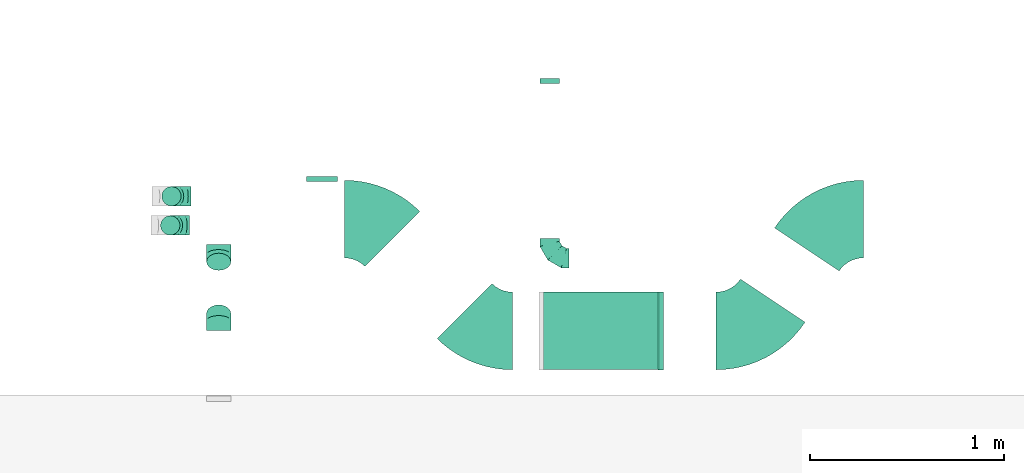
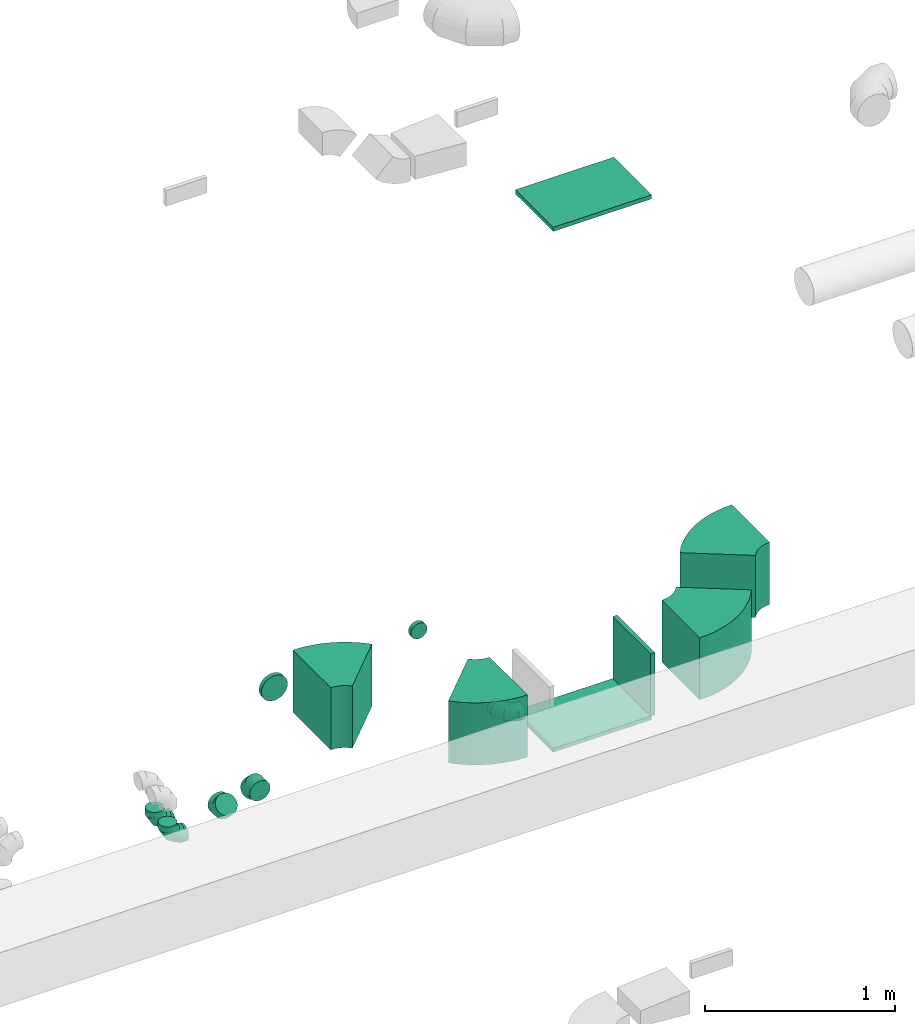
# One storey, part 33 of 62: 14 flow fittings.
"""IFC2X3 building model written with IfcOpenShell, lengths in millimetres."""

from ifc_helpers import new_model, entity, si_unit, converted_unit, derived_unit, direction, frame, frame_2d, origin, origin_2d_with_axis, place, context, subcontext, project, spatial, polyline, circle_curve, parameter, trimmed, segment, composite_curve, rectangle, outline, extrude, faceted_brep, source, transform, mapped, material, type_object, type_shapes, element, save


model = new_model("IFC2X3")

# Units and contexts
model_context = context("Model", 3, precision=0.01, world=origin(), true_north=direction((6.12303176911189e-17, 1.0)))
body_context = subcontext(model_context, "Body", "Model", "MODEL_VIEW")
ifc_project = project(units=[si_unit("LENGTHUNIT", "METRE", prefix="MILLI"), si_unit("AREAUNIT", "SQUARE_METRE"), si_unit("VOLUMEUNIT", "CUBIC_METRE"), converted_unit("PLANEANGLEUNIT", "DEGREE", entity("IfcRatioMeasure", 0.0174532925199433), si_unit("PLANEANGLEUNIT", "RADIAN"), dimensions=[0, 0, 0, 0, 0, 0, 0]), si_unit("MASSUNIT", "GRAM", prefix="KILO"), derived_unit("MASSDENSITYUNIT", [(si_unit("MASSUNIT", "GRAM", prefix="KILO"), 1), (si_unit("LENGTHUNIT", "METRE"), -3)]), derived_unit("MOMENTOFINERTIAUNIT", [(si_unit("LENGTHUNIT", "METRE"), 4)]), si_unit("TIMEUNIT", "SECOND"), si_unit("FREQUENCYUNIT", "HERTZ"), si_unit("THERMODYNAMICTEMPERATUREUNIT", "DEGREE_CELSIUS"), derived_unit("THERMALTRANSMITTANCEUNIT", [(si_unit("MASSUNIT", "GRAM", prefix="KILO"), 1), (si_unit("THERMODYNAMICTEMPERATUREUNIT", "KELVIN"), -1), (si_unit("TIMEUNIT", "SECOND"), -3)]), derived_unit("VOLUMETRICFLOWRATEUNIT", [(si_unit("LENGTHUNIT", "METRE"), 3), (si_unit("TIMEUNIT", "SECOND"), -1)]), derived_unit("MASSFLOWRATEUNIT", [(si_unit("MASSUNIT", "GRAM", prefix="KILO"), 1), (si_unit("TIMEUNIT", "SECOND"), -1)]), derived_unit("ROTATIONALFREQUENCYUNIT", [(si_unit("TIMEUNIT", "SECOND"), -1)]), si_unit("ELECTRICCURRENTUNIT", "AMPERE"), si_unit("ELECTRICVOLTAGEUNIT", "VOLT"), si_unit("POWERUNIT", "WATT"), si_unit("FORCEUNIT", "NEWTON", prefix="KILO"), si_unit("ILLUMINANCEUNIT", "LUX"), si_unit("LUMINOUSFLUXUNIT", "LUMEN"), si_unit("LUMINOUSINTENSITYUNIT", "CANDELA"), derived_unit("USERDEFINED", [(si_unit("MASSUNIT", "GRAM", prefix="KILO"), -1), (si_unit("LENGTHUNIT", "METRE"), -2), (si_unit("TIMEUNIT", "SECOND"), 3), (si_unit("LUMINOUSFLUXUNIT", "LUMEN"), 1)]), derived_unit("LINEARVELOCITYUNIT", [(si_unit("LENGTHUNIT", "METRE"), 1), (si_unit("TIMEUNIT", "SECOND"), -1)]), si_unit("PRESSUREUNIT", "PASCAL"), derived_unit("USERDEFINED", [(si_unit("LENGTHUNIT", "METRE"), -2), (si_unit("MASSUNIT", "GRAM", prefix="KILO"), 1), (si_unit("TIMEUNIT", "SECOND"), -2)]), derived_unit("LINEARFORCEUNIT", [(si_unit("MASSUNIT", "GRAM", prefix="KILO"), 1), (si_unit("LENGTHUNIT", "METRE"), 1), (si_unit("TIMEUNIT", "SECOND"), -2), (si_unit("LENGTHUNIT", "METRE"), -1)]), derived_unit("PLANARFORCEUNIT", [(si_unit("MASSUNIT", "GRAM", prefix="KILO"), 1), (si_unit("LENGTHUNIT", "METRE"), 1), (si_unit("TIMEUNIT", "SECOND"), -2), (si_unit("LENGTHUNIT", "METRE"), -2)])], contexts=[model_context])

# Site, building, storey
site_placement = place(None, origin())
site = spatial("IfcSite", under=ifc_project, at=site_placement, CompositionType="ELEMENT")
building_placement = place(site_placement, origin())
building = spatial("IfcBuilding", under=site, at=building_placement, CompositionType="ELEMENT")
storey_placement = place(building_placement, frame((0.0, 0.0, 24000.0)))
storey = spatial("IfcBuildingStorey", under=building, at=storey_placement, CompositionType="ELEMENT", Elevation=24000.0)

# Flow fittings
ifc_material = material()
duct_fitting_type_1 = type_object("IfcDuctFittingType", PredefinedType="NOTDEFINED", material=ifc_material)
shared_shape_1 = source(origin(), body_context, "Body", "SweptSolid", [
    extrude(rectangle(XDim=26.0960000000093, YDim=400.0, at=origin_2d_with_axis()), frame((6.95, 0.0, -200.0)), (0.0, 0.0, 1.0), 400.0),
])
type_shapes(duct_fitting_type_1, [shared_shape_1])
flow_fitting_1_placement = place(storey_placement, frame((45226.69, 9506.23, 3550.0), z_axis=(0.0, -1.0, 0.0), x_axis=(1.0, 0.0, 0.0)))
element("IfcFlowFitting", 1, at=flow_fitting_1_placement, inside=storey, type_object=duct_fitting_type_1, material=ifc_material, context=body_context, shape_type="MappedRepresentation", body=[
    mapped(shared_shape_1, transform((0.0, 0.0, 0.0), scale=1.0)),
])
duct_fitting_type_2 = type_object("IfcDuctFittingType", PredefinedType="NOTDEFINED", material=ifc_material)
shared_shape_2 = source(origin(), body_context, "Body", "SweptSolid", [
    extrude(rectangle(XDim=24.9999999999999, YDim=600.0, at=origin_2d_with_axis()), frame((12.5, 0.0, -200.0)), (0.0, 0.0, 1.0), 400.0),
])
type_shapes(duct_fitting_type_2, [shared_shape_2])
flow_fitting_2_placement = place(storey_placement, frame((44926.69, 9506.67, 3350.0), z_axis=(0.0, -1.0, 0.0), x_axis=(0.0, 0.0, -1.0)))
element("IfcFlowFitting", 2, at=flow_fitting_2_placement, inside=storey, type_object=duct_fitting_type_2, material=ifc_material, context=body_context, shape_type="MappedRepresentation", body=[
    mapped(shared_shape_2, transform((0.0, 0.0, 0.0), scale=1.0)),
])
duct_fitting_type_3 = type_object("IfcDuctFittingType", PredefinedType="NOTDEFINED", material=ifc_material)
shared_shape_3 = source(origin(), body_context, "Body", "SweptSolid", [
    extrude(rectangle(XDim=26.0960000000009, YDim=600.0, at=origin_2d_with_axis()), frame((6.95, 0.0, -200.0)), (0.0, 0.0, 1.0), 400.0),
])
type_shapes(duct_fitting_type_3, [shared_shape_3])
flow_fitting_3_placement = place(storey_placement, frame((44926.69, 9506.67, 6700.0), z_axis=(0.0, -1.0, 0.0), x_axis=(0.0, 0.0, -1.0)))
element("IfcFlowFitting", 3, at=flow_fitting_3_placement, inside=storey, type_object=duct_fitting_type_3, material=ifc_material, context=body_context, shape_type="MappedRepresentation", body=[
    mapped(shared_shape_3, transform((0.0, 0.0, 0.0), scale=1.0)),
])
duct_fitting_type_4 = type_object("IfcDuctFittingType", PredefinedType="NOTDEFINED", material=ifc_material)
shared_shape_4 = source(origin(), body_context, "Body", "Brep", [
    faceted_brep([(-100.0, 0.0, -50.0), (-100.0, -12.94, -48.3), (-100.0, -25.0, -43.3), (-100.0, -35.36, -35.36), (-100.0, -43.3, -25.0), (-100.0, -48.3, -12.94), (-100.0, -50.0, 0.0), (-100.0, -48.3, 12.94), (-100.0, -43.3, 25.0), (-100.0, -35.36, 35.36), (-100.0, -25.0, 43.3), (-100.0, -12.94, 48.3), (-100.0, 0.0, 50.0), (-100.0, 12.94, 48.3), (-100.0, 25.0, 43.3), (-100.0, 35.36, 35.36), (-100.0, 43.3, 25.0), (-100.0, 48.3, 12.94), (-100.0, 50.0, 0.0), (-100.0, 48.3, -12.94), (-100.0, 43.3, -25.0), (-100.0, 35.36, -35.36), (-100.0, 25.0, -43.3), (-100.0, 12.94, -48.3), (-76.67, 12.94, 48.3), (-79.9, 25.0, 43.3), (-73.21, 0.0, 50.0), (-82.68, 35.36, 35.36), (-86.15, 48.3, 12.94), (-86.6, 50.0, 0.0), (-84.81, 43.3, 25.0), (-84.81, 43.3, -25.0), (-82.68, 35.36, -35.36), (-86.15, 48.3, -12.94), (-76.67, 12.94, -48.3), (-73.21, 0.0, -50.0), (-79.9, 25.0, -43.3), (-69.74, -12.94, -48.3), (-66.51, -25.0, -43.3), (-63.73, -35.36, -35.36), (-61.6, -43.3, -25.0), (-60.26, -48.3, -12.94), (-59.81, -50.0, 0.0), (-60.26, -48.3, 12.94), (-61.6, -43.3, 25.0), (-63.73, -35.36, 35.36), (-66.51, -25.0, 43.3), (-69.74, -12.94, 48.3), (-36.27, 36.27, 48.3), (-45.1, 45.1, 43.3), (-26.79, 26.79, 50.0), (-52.68, 52.68, 35.36), (-58.49, 58.49, 25.0), (-62.15, 62.15, 12.94), (-63.4, 63.4, 0.0), (-62.15, 62.15, -12.94), (-58.49, 58.49, -25.0), (-52.68, 52.68, -35.36), (-36.27, 36.27, -48.3), (-26.79, 26.79, -50.0), (-45.1, 45.1, -43.3), (-17.32, 17.32, -48.3), (-8.49, 8.49, -43.3), (-0.91, 0.91, -35.36), (4.9, -4.9, -25.0), (8.56, -8.56, -12.94), (9.81, -9.81, 0.0), (8.56, -8.56, 12.94), (4.9, -4.9, 25.0), (-0.91, 0.91, 35.36), (-8.49, 8.49, 43.3), (-17.32, 17.32, 48.3), (-12.94, 76.67, 48.3), (-25.0, 79.9, 43.3), (0.0, 73.21, 50.0), (-35.36, 82.68, 35.36), (-43.3, 84.81, 25.0), (-48.3, 86.15, 12.94), (-50.0, 86.6, 0.0), (-48.3, 86.15, -12.94), (-43.3, 84.81, -25.0), (-35.36, 82.68, -35.36), (-12.94, 76.67, -48.3), (0.0, 73.21, -50.0), (-25.0, 79.9, -43.3), (12.94, 69.74, -48.3), (25.0, 66.51, -43.3), (35.36, 63.73, -35.36), (43.3, 61.6, -25.0), (48.3, 60.26, -12.94), (50.0, 59.81, 0.0), (48.3, 60.26, 12.94), (43.3, 61.6, 25.0), (35.36, 63.73, 35.36), (25.0, 66.51, 43.3), (12.94, 69.74, 48.3), (-12.94, 100.0, -48.3), (-25.0, 100.0, -43.3), (-35.36, 100.0, -35.36), (-43.3, 100.0, -25.0), (-48.3, 100.0, -12.94), (-50.0, 100.0, 0.0), (-48.3, 100.0, 12.94), (-43.3, 100.0, 25.0), (-35.36, 100.0, 35.36), (-25.0, 100.0, 43.3), (-12.94, 100.0, 48.3), (0.0, 100.0, 50.0), (12.94, 100.0, 48.3), (25.0, 100.0, 43.3), (35.36, 100.0, 35.36), (43.3, 100.0, 25.0), (48.3, 100.0, 12.94), (50.0, 100.0, 0.0), (48.3, 100.0, -12.94), (43.3, 100.0, -25.0), (35.36, 100.0, -35.36), (25.0, 100.0, -43.3), (12.94, 100.0, -48.3), (0.0, 100.0, -50.0)], [[[0, 1, 2, 3, 4, 5, 6, 7, 8, 9, 10, 11, 12, 13, 14, 15, 16, 17, 18, 19, 20, 21, 22, 23]], [[24, 25, 14, 13]], [[26, 24, 13, 12]], [[14, 25, 27, 15]], [[28, 29, 18, 17]], [[30, 28, 17, 16]], [[15, 27, 30, 16]], [[20, 31, 32, 21]], [[33, 31, 20, 19]], [[18, 29, 33, 19]], [[34, 35, 0, 23]], [[36, 34, 23, 22]], [[32, 36, 22, 21]], [[2, 1, 37, 38]], [[3, 2, 38, 39]], [[0, 35, 37, 1]], [[5, 4, 40, 41]], [[6, 5, 41, 42]], [[3, 39, 40, 4]], [[6, 42, 43, 7]], [[7, 43, 44, 8]], [[8, 44, 45, 9]], [[10, 46, 47, 11]], [[11, 47, 26, 12]], [[10, 9, 45, 46]], [[48, 49, 25, 24]], [[50, 48, 24, 26]], [[27, 25, 49, 51]], [[52, 53, 28, 30]], [[51, 52, 30, 27]], [[29, 28, 53, 54]], [[55, 56, 31, 33]], [[54, 55, 33, 29]], [[57, 32, 31, 56]], [[58, 59, 35, 34]], [[60, 58, 34, 36]], [[57, 60, 36, 32]], [[37, 35, 59, 61]], [[38, 37, 61, 62]], [[39, 38, 62, 63]], [[41, 40, 64, 65]], [[42, 41, 65, 66]], [[63, 64, 40, 39]], [[43, 42, 66, 67]], [[44, 43, 67, 68]], [[68, 69, 45, 44]], [[46, 45, 69, 70]], [[47, 46, 70, 71]], [[26, 47, 71, 50]], [[72, 73, 49, 48]], [[74, 72, 48, 50]], [[51, 49, 73, 75]], [[76, 77, 53, 52]], [[75, 76, 52, 51]], [[54, 53, 77, 78]], [[79, 80, 56, 55]], [[78, 79, 55, 54]], [[81, 57, 56, 80]], [[82, 83, 59, 58]], [[84, 82, 58, 60]], [[81, 84, 60, 57]], [[61, 59, 83, 85]], [[62, 61, 85, 86]], [[63, 62, 86, 87]], [[65, 64, 88, 89]], [[66, 65, 89, 90]], [[87, 88, 64, 63]], [[67, 66, 90, 91]], [[68, 67, 91, 92]], [[92, 93, 69, 68]], [[70, 69, 93, 94]], [[71, 70, 94, 95]], [[50, 71, 95, 74]], [[96, 97, 98, 99, 100, 101, 102, 103, 104, 105, 106, 107, 108, 109, 110, 111, 112, 113, 114, 115, 116, 117, 118, 119]], [[72, 74, 107, 106]], [[73, 72, 106, 105]], [[75, 73, 105, 104]], [[77, 76, 103, 102]], [[78, 77, 102, 101]], [[75, 104, 103, 76]], [[78, 101, 100, 79]], [[79, 100, 99, 80]], [[80, 99, 98, 81]], [[96, 119, 83, 82]], [[97, 96, 82, 84]], [[84, 81, 98, 97]], [[83, 119, 118, 85]], [[85, 118, 117, 86]], [[86, 117, 116, 87]], [[88, 115, 114, 89]], [[89, 114, 113, 90]], [[87, 116, 115, 88]], [[91, 90, 113, 112]], [[92, 91, 112, 111]], [[93, 92, 111, 110]], [[95, 94, 109, 108]], [[74, 95, 108, 107]], [[110, 109, 94, 93]]]),
])
type_shapes(duct_fitting_type_4, [shared_shape_4])
for number, where, z_axis, x_axis in (
    (4, (44661.37, 9881.53, 3200.0), (0.0, 0.0, 1.0), (0.0, -1.0, 0.0)),
    (5, (42706.67, 10049.93, 3000.0), (0.0, -1.0, 0.0), (0.0, 0.0, -1.0)),
    (6, (42712.73, 10199.94, 3000.0), (0.0, -1.0, 0.0), (0.0, 0.0, -1.0)),
):
    element("IfcFlowFitting", number, at=place(storey_placement, frame(where, z_axis=z_axis, x_axis=x_axis)), inside=storey, type_object=duct_fitting_type_4, material=ifc_material, context=body_context, shape_type="MappedRepresentation", body=[
        mapped(shared_shape_4, transform((0.0, 0.0, 0.0), scale=1.0)),
    ])
duct_fitting_type_5 = type_object("IfcDuctFittingType", PredefinedType="NOTDEFINED", material=ifc_material)
shared_shape_5 = source(origin(), body_context, "Body", "Brep", [
    faceted_brep([(-51.78, 0.0, -62.5), (-51.78, -16.18, -60.37), (-51.78, -31.25, -54.13), (-51.78, -44.19, -44.19), (-51.78, -54.13, -31.25), (-51.78, -60.37, -16.18), (-51.78, -62.5, 0.0), (-51.78, -60.37, 16.18), (-51.78, -54.13, 31.25), (-51.78, -44.19, 44.19), (-51.78, -31.25, 54.13), (-51.78, -16.18, 60.37), (-51.78, 0.0, 62.5), (-51.78, 16.18, 60.37), (-51.78, 31.25, 54.13), (-51.78, 44.19, 44.19), (-51.78, 54.13, 31.25), (-51.78, 60.37, 16.18), (-51.78, 62.5, 0.0), (-51.78, 60.37, -16.18), (-51.78, 54.13, -31.25), (-51.78, 44.19, -44.19), (-51.78, 31.25, -54.13), (-51.78, 16.18, -60.37), (-6.7, 16.18, 60.37), (-12.94, 31.25, 54.13), (0.0, 0.0, 62.5), (-18.31, 44.19, 44.19), (-22.42, 54.13, 31.25), (-25.01, 60.37, 16.18), (-25.89, 62.5, 0.0), (-25.01, 60.37, -16.18), (-22.42, 54.13, -31.25), (-18.31, 44.19, -44.19), (-6.7, 16.18, -60.37), (0.0, 0.0, -62.5), (-12.94, 31.25, -54.13), (6.7, -16.18, -60.37), (12.94, -31.25, -54.13), (18.31, -44.19, -44.19), (22.42, -54.13, -31.25), (25.01, -60.37, -16.18), (25.89, -62.5, 0.0), (25.01, -60.37, 16.18), (22.42, -54.13, 31.25), (18.31, -44.19, 44.19), (12.94, -31.25, 54.13), (6.7, -16.18, 60.37), (25.17, 48.05, 60.37), (14.51, 58.71, 54.13), (36.61, 36.61, 62.5), (5.36, 67.86, 44.19), (-1.66, 74.88, 31.25), (-6.08, 79.3, 16.18), (-7.58, 80.81, 0.0), (-6.08, 79.3, -16.18), (-1.66, 74.88, -31.25), (5.36, 67.86, -44.19), (14.51, 58.71, -54.13), (25.17, 48.05, -60.37), (36.61, 36.61, -62.5), (48.05, 25.17, -60.37), (58.71, 14.51, -54.13), (67.86, 5.36, -44.19), (74.88, -1.66, -31.25), (79.3, -6.08, -16.18), (80.81, -7.58, 0.0), (79.3, -6.08, 16.18), (74.88, -1.66, 31.25), (67.86, 5.36, 44.19), (58.71, 14.51, 54.13), (48.05, 25.17, 60.37)], [[[0, 1, 2, 3, 4, 5, 6, 7, 8, 9, 10, 11, 12, 13, 14, 15, 16, 17, 18, 19, 20, 21, 22, 23]], [[24, 25, 14, 13]], [[26, 24, 13, 12]], [[27, 15, 14, 25]], [[28, 29, 17, 16]], [[28, 16, 15, 27]], [[30, 18, 17, 29]], [[31, 32, 20, 19]], [[30, 31, 19, 18]], [[21, 20, 32, 33]], [[34, 35, 0, 23]], [[36, 34, 23, 22]], [[33, 36, 22, 21]], [[1, 0, 35, 37]], [[2, 1, 37, 38]], [[38, 39, 3, 2]], [[5, 4, 40, 41]], [[6, 5, 41, 42]], [[39, 40, 4, 3]], [[6, 42, 43, 7]], [[7, 43, 44, 8]], [[8, 44, 45, 9]], [[9, 45, 46, 10]], [[10, 46, 47, 11]], [[26, 12, 11, 47]], [[48, 49, 25, 24]], [[50, 48, 24, 26]], [[27, 25, 49, 51]], [[29, 28, 52, 53]], [[30, 29, 53, 54]], [[51, 52, 28, 27]], [[30, 54, 55, 31]], [[31, 55, 56, 32]], [[57, 33, 32, 56]], [[36, 58, 59, 34]], [[34, 59, 60, 35]], [[58, 36, 33, 57]], [[35, 60, 61, 37]], [[37, 61, 62, 38]], [[63, 39, 38, 62]], [[40, 64, 65, 41]], [[41, 65, 66, 42]], [[64, 40, 39, 63]], [[43, 42, 66, 67]], [[44, 43, 67, 68]], [[68, 69, 45, 44]], [[47, 46, 70, 71]], [[26, 47, 71, 50]], [[69, 70, 46, 45]], [[59, 58, 57, 56, 55, 54, 53, 52, 51, 49, 48, 50, 71, 70, 69, 68, 67, 66, 65, 64, 63, 62, 61, 60]]]),
])
type_shapes(duct_fitting_type_5, [shared_shape_5])
for number, where, z_axis, x_axis in (
    (7, (42956.24, 9559.38, 3540.0), (-1.0, 0.0, 0.0), (0.0, 1.0, 0.0)),
    (8, (42956.24, 9899.38, 3200.0), (1.0, 0.0, 0.0), (0.0, 0.707106781186503, -0.707106781186593)),
):
    element("IfcFlowFitting", number, at=place(storey_placement, frame(where, z_axis=z_axis, x_axis=x_axis)), inside=storey, type_object=duct_fitting_type_5, material=ifc_material, context=body_context, shape_type="MappedRepresentation", body=[
        mapped(shared_shape_5, transform((0.0, 0.0, 0.0), scale=1.0)),
    ])
duct_fitting_type_6 = type_object("IfcDuctFittingType", PredefinedType="NOTDEFINED", material=ifc_material)
shared_shape_6 = source(origin(), body_context, "Body", "Brep", [
    faceted_brep([(20.0, 0.0, -80.0), (20.0, 20.71, -77.27), (20.0, 40.0, -69.28), (20.0, 56.57, -56.57), (20.0, 69.28, -40.0), (20.0, 77.27, -20.71), (20.0, 80.0, 0.0), (20.0, 77.27, 20.71), (20.0, 69.28, 40.0), (20.0, 56.57, 56.57), (20.0, 40.0, 69.28), (20.0, 20.71, 77.27), (20.0, 0.0, 80.0), (20.0, -20.71, 77.27), (20.0, -40.0, 69.28), (20.0, -56.57, 56.57), (20.0, -69.28, 40.0), (20.0, -77.27, 20.71), (20.0, -80.0, 0.0), (20.0, -77.27, -20.71), (20.0, -69.28, -40.0), (20.0, -56.57, -56.57), (20.0, -40.0, -69.28), (20.0, -20.71, -77.27), (0.0, 0.0, 80.0), (-6.1, 0.0, 80.0), (-6.1, -20.71, 77.27), (0.0, -20.71, 77.27), (-6.1, -40.0, 69.28), (0.0, -40.0, 69.28), (0.0, -56.57, 56.57), (-6.1, -56.57, 56.57), (0.0, -69.28, 40.0), (-6.1, -69.28, 40.0), (-6.1, -77.27, 20.71), (0.0, -77.27, 20.71), (-6.1, -80.0, 0.0), (0.0, -80.0, 0.0), (-6.1, -77.27, -20.71), (0.0, -77.27, -20.71), (-6.1, -69.28, -40.0), (0.0, -69.28, -40.0), (0.0, -56.57, -56.57), (-6.1, -56.57, -56.57), (0.0, -40.0, -69.28), (-6.1, -40.0, -69.28), (-6.1, -20.71, -77.27), (0.0, -20.71, -77.27), (-6.1, 0.0, -80.0), (0.0, 0.0, -80.0), (-6.1, 20.71, -77.27), (0.0, 20.71, -77.27), (-6.1, 40.0, -69.28), (0.0, 40.0, -69.28), (0.0, 56.57, -56.57), (-6.1, 56.57, -56.57), (0.0, 69.28, -40.0), (-6.1, 69.28, -40.0), (-6.1, 77.27, -20.71), (0.0, 77.27, -20.71), (-6.1, 80.0, 0.0), (0.0, 80.0, 0.0), (-6.1, 77.27, 20.71), (0.0, 77.27, 20.71), (-6.1, 69.28, 40.0), (0.0, 69.28, 40.0), (0.0, 56.57, 56.57), (-6.1, 56.57, 56.57), (0.0, 40.0, 69.28), (-6.1, 40.0, 69.28), (-6.1, 20.71, 77.27), (0.0, 20.71, 77.27)], [[[0, 1, 2, 3, 4, 5, 6, 7, 8, 9, 10, 11, 12, 13, 14, 15, 16, 17, 18, 19, 20, 21, 22, 23]], [[13, 12, 24, 25, 26, 27]], [[14, 13, 27, 26, 28, 29]], [[30, 15, 14, 29, 28, 31]], [[17, 16, 32, 33, 34, 35]], [[18, 17, 35, 34, 36, 37]], [[32, 16, 15, 30, 31, 33]], [[19, 18, 37, 36, 38, 39]], [[20, 19, 39, 38, 40, 41]], [[42, 21, 20, 41, 40, 43]], [[23, 22, 44, 45, 46, 47]], [[0, 23, 47, 46, 48, 49]], [[44, 22, 21, 42, 43, 45]], [[1, 0, 49, 48, 50, 51]], [[2, 1, 51, 50, 52, 53]], [[54, 3, 2, 53, 52, 55]], [[5, 4, 56, 57, 58, 59]], [[6, 5, 59, 58, 60, 61]], [[56, 4, 3, 54, 55, 57]], [[7, 6, 61, 60, 62, 63]], [[8, 7, 63, 62, 64, 65]], [[66, 9, 8, 65, 64, 67]], [[11, 10, 68, 69, 70, 71]], [[12, 11, 71, 70, 25, 24]], [[68, 10, 9, 66, 67, 69]], [[46, 45, 43, 40, 38, 36, 34, 33, 31, 28, 26, 25, 70, 69, 67, 64, 62, 60, 58, 57, 55, 52, 50, 48]]]),
])
type_shapes(duct_fitting_type_6, [shared_shape_6])
flow_fitting_4_placement = place(storey_placement, frame((43488.68, 10282.41, 3550.0), z_axis=(0.0, 0.0, -1.0), x_axis=(0.0, 1.0, 0.0)))
element("IfcFlowFitting", 9, at=flow_fitting_4_placement, inside=storey, type_object=duct_fitting_type_6, material=ifc_material, context=body_context, shape_type="MappedRepresentation", body=[
    mapped(shared_shape_6, transform((0.0, 0.0, 0.0), scale=1.0)),
])
duct_fitting_type_7 = type_object("IfcDuctFittingType", PredefinedType="NOTDEFINED", material=ifc_material)
shared_shape_7 = source(origin(), body_context, "Body", "Brep", [
    faceted_brep([(20.0, 12.94, -48.3), (20.0, 25.0, -43.3), (20.0, 35.36, -35.36), (20.0, 43.3, -25.0), (20.0, 48.3, -12.94), (20.0, 50.0, 0.0), (20.0, 48.3, 12.94), (20.0, 43.3, 25.0), (20.0, 35.36, 35.36), (20.0, 25.0, 43.3), (20.0, 12.94, 48.3), (20.0, 0.0, 50.0), (20.0, -12.94, 48.3), (20.0, -25.0, 43.3), (20.0, -35.36, 35.36), (20.0, -43.3, 25.0), (20.0, -48.3, 12.94), (20.0, -50.0, 0.0), (20.0, -48.3, -12.94), (20.0, -43.3, -25.0), (20.0, -35.36, -35.36), (20.0, -25.0, -43.3), (20.0, -12.94, -48.3), (20.0, 0.0, -50.0), (0.0, 0.0, 50.0), (0.0, 12.94, 48.3), (-6.1, 12.94, 48.3), (-6.1, 0.0, 50.0), (0.0, 25.0, 43.3), (-6.1, 25.0, 43.3), (0.0, 35.36, 35.36), (-6.1, 35.36, 35.36), (0.0, 43.3, 25.0), (0.0, 48.3, 12.94), (-6.1, 48.3, 12.94), (-6.1, 43.3, 25.0), (0.0, 50.0, 0.0), (-6.1, 50.0, 0.0), (0.0, 48.3, -12.94), (-6.1, 48.3, -12.94), (0.0, 43.3, -25.0), (-6.1, 43.3, -25.0), (0.0, 35.36, -35.36), (-6.1, 35.36, -35.36), (0.0, 25.0, -43.3), (0.0, 12.94, -48.3), (-6.1, 12.94, -48.3), (-6.1, 25.0, -43.3), (0.0, 0.0, -50.0), (-6.1, 0.0, -50.0), (0.0, -12.94, -48.3), (-6.1, -12.94, -48.3), (0.0, -25.0, -43.3), (-6.1, -25.0, -43.3), (0.0, -35.36, -35.36), (-6.1, -35.36, -35.36), (0.0, -43.3, -25.0), (0.0, -48.3, -12.94), (-6.1, -48.3, -12.94), (-6.1, -43.3, -25.0), (0.0, -50.0, 0.0), (-6.1, -50.0, 0.0), (0.0, -48.3, 12.94), (-6.1, -48.3, 12.94), (0.0, -43.3, 25.0), (-6.1, -43.3, 25.0), (0.0, -35.36, 35.36), (-6.1, -35.36, 35.36), (0.0, -25.0, 43.3), (0.0, -12.94, 48.3), (-6.1, -12.94, 48.3), (-6.1, -25.0, 43.3)], [[[0, 1, 2, 3, 4, 5, 6, 7, 8, 9, 10, 11, 12, 13, 14, 15, 16, 17, 18, 19, 20, 21, 22, 23]], [[24, 11, 10, 25, 26, 27]], [[25, 10, 9, 28, 29, 26]], [[28, 9, 8, 30, 31, 29]], [[32, 7, 6, 33, 34, 35]], [[33, 6, 5, 36, 37, 34]], [[30, 8, 7, 32, 35, 31]], [[36, 5, 4, 38, 39, 37]], [[38, 4, 3, 40, 41, 39]], [[40, 3, 2, 42, 43, 41]], [[44, 1, 0, 45, 46, 47]], [[45, 0, 23, 48, 49, 46]], [[42, 2, 1, 44, 47, 43]], [[48, 23, 22, 50, 51, 49]], [[50, 22, 21, 52, 53, 51]], [[52, 21, 20, 54, 55, 53]], [[56, 19, 18, 57, 58, 59]], [[57, 18, 17, 60, 61, 58]], [[54, 20, 19, 56, 59, 55]], [[60, 17, 16, 62, 63, 61]], [[62, 16, 15, 64, 65, 63]], [[64, 15, 14, 66, 67, 65]], [[68, 13, 12, 69, 70, 71]], [[69, 12, 11, 24, 27, 70]], [[66, 14, 13, 68, 71, 67]], [[49, 51, 53, 55, 59, 58, 61, 63, 65, 67, 71, 70, 27, 26, 29, 31, 35, 34, 37, 39, 41, 43, 47, 46]]]),
])
type_shapes(duct_fitting_type_7, [shared_shape_7])
flow_fitting_5_placement = place(storey_placement, frame((44661.37, 10801.83, 3200.0), z_axis=(-1.0, 0.0, 0.0), x_axis=(0.0, -1.0, 0.0)))
element("IfcFlowFitting", 10, at=flow_fitting_5_placement, inside=storey, type_object=duct_fitting_type_7, material=ifc_material, context=body_context, shape_type="MappedRepresentation", body=[
    mapped(shared_shape_7, transform((0.0, 0.0, 0.0), scale=1.0)),
])
duct_fitting_type_8 = type_object("IfcDuctFittingType", PredefinedType="NOTDEFINED", material=ifc_material)
shared_shape_8 = source(origin(), body_context, "Body", "SweptSolid", [
    extrude(outline(composite_curve([segment(polyline([(-277.99, -145.65), (122.01, -145.65)]), True, "CONTINUOUS"), segment(trimmed(circle_curve(frame_2d((272.01, -145.65), x_axis=(-0.554353814771957, 0.832281111192486)), 150.0), [parameter(0.0)], [parameter(56.3337813241013)], True, "PARAMETER"), False, "CONTINUOUS"), segment(polyline([(188.86, -20.81), (-32.88, 312.11)]), True, "CONTINUOUS"), segment(trimmed(circle_curve(frame_2d((272.01, -145.65), x_axis=(-0.554353814771957, 0.832281111192486)), 550.0), [parameter(0.0)], [parameter(56.3337813241013)], True, "PARAMETER"), True, "CONTINUOUS")], self_intersect=False)), frame((-41.76, 77.99, -200.0), z_axis=(0.0, 0.0, 1.0), x_axis=(-0.832281111192477, 0.554353814771952, 0.0)), (0.0, 0.0, 1.0), 400.0),
])
type_shapes(duct_fitting_type_8, [shared_shape_8])
flow_fitting_6_placement = place(storey_placement, frame((45706.72, 9506.23, 3550.0)))
element("IfcFlowFitting", 11, at=flow_fitting_6_placement, inside=storey, type_object=duct_fitting_type_8, material=ifc_material, context=body_context, shape_type="MappedRepresentation", body=[
    mapped(shared_shape_8, transform((0.0, 0.0, 0.0), scale=1.0)),
])
flow_fitting_7_placement = place(storey_placement, frame((46090.49, 10082.41, 3550.0), z_axis=(0.0, 0.0, 1.0), x_axis=(-1.0, 0.0, 0.0)))
element("IfcFlowFitting", 12, at=flow_fitting_7_placement, inside=storey, type_object=duct_fitting_type_8, material=ifc_material, context=body_context, shape_type="MappedRepresentation", body=[
    mapped(shared_shape_8, transform((0.0, 0.0, 0.0), scale=1.0)),
])
duct_fitting_type_9 = type_object("IfcDuctFittingType", PredefinedType="NOTDEFINED", material=ifc_material)
shared_shape_9 = source(origin(), body_context, "Body", "SweptSolid", [
    extrude(outline(composite_curve([segment(polyline([(-251.26, -123.74), (148.74, -123.74)]), True, "CONTINUOUS"), segment(trimmed(circle_curve(frame_2d((298.74, -123.74), x_axis=(-0.707106781186546, 0.707106781186546)), 150.0), [parameter(0.0)], [parameter(45.0)], True, "PARAMETER"), False, "CONTINUOUS"), segment(polyline([(192.68, -17.68), (-90.17, 265.17)]), True, "CONTINUOUS"), segment(trimmed(circle_curve(frame_2d((298.74, -123.74), x_axis=(-0.707106781186546, 0.707106781186546)), 550.0), [parameter(0.0)], [parameter(45.0)], True, "PARAMETER"), True, "CONTINUOUS")], self_intersect=False)), frame((-21.23, 51.26, -200.0), z_axis=(0.0, 0.0, 1.0), x_axis=(-0.707106781186547, 0.707106781186548, 0.0)), (0.0, 0.0, 1.0), 400.0),
])
type_shapes(duct_fitting_type_9, [shared_shape_9])
for number, where, z_axis, x_axis in (
    (13, (43748.85, 10082.41, 3550.0), (0.0, 0.0, 1.0), (-0.707106781186547, 0.707106781186548, 0.0)),
    (14, (44325.03, 9506.23, 3550.0), (0.0, 0.0, 1.0), (0.707106781186517, -0.707106781186578, 0.0)),
):
    element("IfcFlowFitting", number, at=place(storey_placement, frame(where, z_axis=z_axis, x_axis=x_axis)), inside=storey, type_object=duct_fitting_type_9, material=ifc_material, context=body_context, shape_type="MappedRepresentation", body=[
        mapped(shared_shape_9, transform((0.0, 0.0, 0.0), scale=1.0)),
    ])

save(model, "model.ifc")
